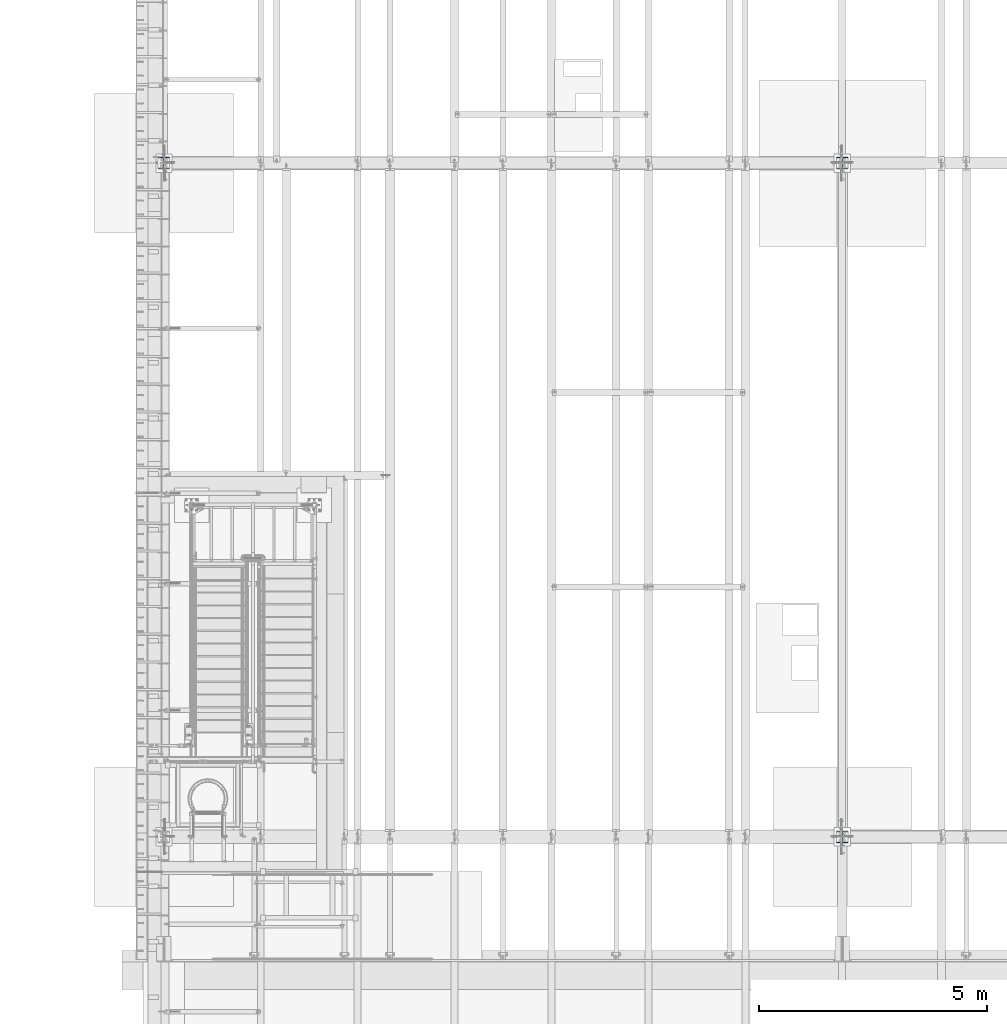
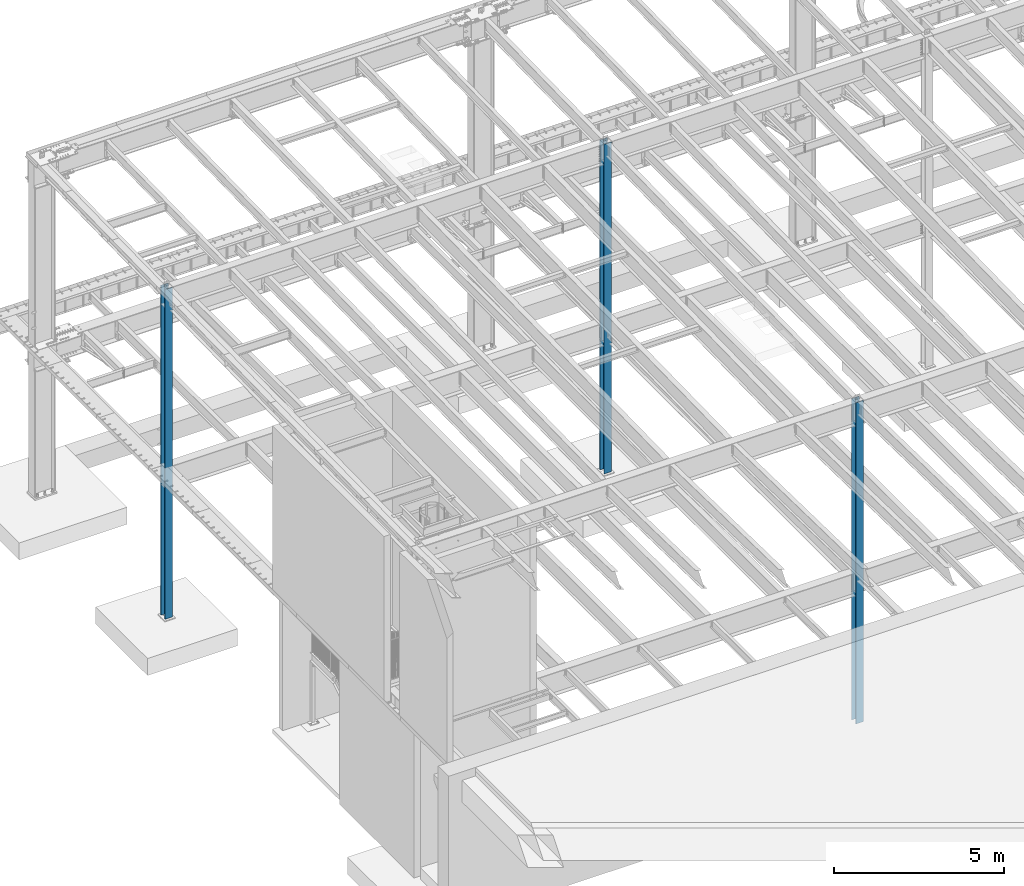
# One storey, part 907 of 1763: 3 columns, 3 elements without a shape of their own.
"""IFC2X3 building model written with IfcOpenShell, lengths in millimetres."""

import ifcopenshell
import ifcopenshell.guid

model = None  # the IFC model being written
_history = None  # IfcOwnerHistory: only IFC2X3 demands one
_inside = {}  # id of a spatial element -> (the spatial element, [elements in it])
_under = {}  # id of a project, library or spatial element -> (it, [spatial elements below it])
_declared = {}  # id of a project -> (the project, [libraries it declares])
_typed = {}  # id of a type object -> (the type object, [elements of that type])
_made_of = {}  # id of a material, layer set ... -> (it, [elements and type objects made of it])


def new_model(schema):
    """Start an empty IFC model of exactly this schema.

    Asked for "IFC4X3", IfcOpenShell would pick the latest addendum, in which some entities
    have other attributes; the version numbers below select the first issue.
    IFC2X3 requires an IfcOwnerHistory on every rooted entity: one is made here for all.
    """
    global model, _history
    if schema == "IFC4X3":
        model = ifcopenshell.file(schema_version=(4, 3, 0, 0))
    else:
        model = ifcopenshell.file(schema=schema)
    _inside.clear()
    _under.clear()
    _declared.clear()
    _typed.clear()
    _made_of.clear()
    _history = None
    if model.schema == "IFC2X3":
        org = make("IfcOrganization", Name="unknown")
        user = make(
            "IfcPersonAndOrganization",
            ThePerson=make("IfcPerson", FamilyName="unknown"),
            TheOrganization=org,
        )
        app = make(
            "IfcApplication",
            ApplicationDeveloper=org,
            Version="unknown",
            ApplicationFullName="unknown",
            ApplicationIdentifier="unknown",
        )
        _history = make(
            "IfcOwnerHistory",
            OwningUser=user,
            OwningApplication=app,
            ChangeAction="ADDED",
            CreationDate=0,
        )
    return model


def make(cls, **values):
    """One entity of the class cls with the attributes given. An attribute that is None is left unset."""
    return model.create_entity(
        cls, **{name: value for name, value in values.items() if value is not None}
    )


def rooted(cls, **values):
    """An entity with a GlobalId (a new one), such as an element, a storey or a relation."""
    return make(cls, GlobalId=ifcopenshell.guid.new(), OwnerHistory=_history, **values)


def si_unit(unit_type, name, prefix=None):
    """IfcSIUnit, for example si_unit("LENGTHUNIT", "METRE", prefix="MILLI")."""
    return make("IfcSIUnit", UnitType=unit_type, Prefix=prefix, Name=name)


def assignment(units):
    """IfcUnitAssignment: the units of a project."""
    return None if units is None else make("IfcUnitAssignment", Units=units)


def point(xyz):
    """IfcCartesianPoint."""
    return None if xyz is None else make("IfcCartesianPoint", Coordinates=xyz)


def direction(xyz):
    """IfcDirection."""
    return None if xyz is None else make("IfcDirection", DirectionRatios=xyz)


def frame(location, z_axis=None, x_axis=None):
    """IfcAxis2Placement3D, a coordinate frame: its origin and axes. An axis left out is left unset."""
    return make(
        "IfcAxis2Placement3D",
        Location=point(location),
        Axis=direction(z_axis),
        RefDirection=direction(x_axis),
    )


def origin_with_axes():
    """The frame at (0, 0, 0) with the z axis (0, 0, 1) and the x axis (1, 0, 0) written out."""
    return frame((0.0, 0.0, 0.0), z_axis=(0.0, 0.0, 1.0), x_axis=(1.0, 0.0, 0.0))


def place(relative_to, where):
    """IfcLocalPlacement: puts the frame where relative to a parent placement (None: the world)."""
    return make(
        "IfcLocalPlacement", PlacementRelTo=relative_to, RelativePlacement=where
    )


def context(
    kind, dimensions, precision=None, world=None, true_north=None, identifier=None
):
    """IfcGeometricRepresentationContext, for example the 3D "Model" context."""
    return make(
        "IfcGeometricRepresentationContext",
        ContextIdentifier=identifier,
        ContextType=kind,
        CoordinateSpaceDimension=dimensions,
        Precision=precision,
        WorldCoordinateSystem=world,
        TrueNorth=true_north,
    )


def subcontext(parent, identifier, kind, view, scale=None):
    """IfcGeometricRepresentationSubContext, for example "Body" below "Model"."""
    return make(
        "IfcGeometricRepresentationSubContext",
        ContextIdentifier=identifier,
        ContextType=kind,
        ParentContext=parent,
        TargetScale=scale,
        TargetView=view,
    )


def project(units=None, contexts=None):
    """IfcProject with its units and contexts."""
    return rooted(
        "IfcProject",
        Name="project",
        RepresentationContexts=contexts,
        UnitsInContext=assignment(units),
    )


def spatial(cls, under=None, at=None, **own):
    """A site, building, storey or space (cls), placed at a placement, below another one or the project."""
    s = rooted(cls, ObjectPlacement=at, **own)
    if under is not None:
        _under.setdefault(under.id(), (under, []))[1].append(s)
    return s


def faces_of(points, faces, orient=None, outer=None):
    """IfcFace entities. A face is a list of loops; a loop is a list of indices into points, from 0.

    orient and outer hold one flag for each loop. By default every Orientation is true, the
    first loop of a face is its IfcFaceOuterBound and the others are IfcFaceBound.
    """
    made = []
    for i, loops in enumerate(faces):
        bounds = []
        for j, loop in enumerate(loops):
            is_outer = j == 0 if outer is None else outer[i][j]
            bounds.append(
                make(
                    "IfcFaceOuterBound" if is_outer else "IfcFaceBound",
                    Bound=make("IfcPolyLoop", Polygon=[points[k] for k in loop]),
                    Orientation=True if orient is None else orient[i][j],
                )
            )
        made.append(make("IfcFace", Bounds=bounds))
    return made


def faceted_brep(points, faces, orient=None, outer=None, voids=None):
    """IfcFacetedBrep: a solid bounded by flat faces; with voids (closed shells), ...WithVoids."""
    shared = [point(p) for p in points]
    hull = make("IfcClosedShell", CfsFaces=faces_of(shared, faces, orient, outer))
    if voids is None:
        return make("IfcFacetedBrep", Outer=hull)
    return make(
        "IfcFacetedBrepWithVoids",
        Outer=hull,
        Voids=[
            make(cls, CfsFaces=faces_of(shared, fs, o, b)) for cls, fs, o, b in voids
        ],
    )


def shape(context_of_items, identifier, shape_type, items):
    """IfcShapeRepresentation: the items that make up one representation, for example the "Body"."""
    return make(
        "IfcShapeRepresentation",
        ContextOfItems=context_of_items,
        RepresentationIdentifier=identifier,
        RepresentationType=shape_type,
        Items=items,
    )


def material(Name=None, Category=None):
    """IfcMaterial."""
    return make("IfcMaterial", Name=Name, Category=Category)


def made_of(thing, what):
    """Note that an element or type object is made of a material, layer set ...; save() writes the relation."""
    if what is not None:
        _made_of.setdefault(what.id(), (what, []))[1].append(thing)
    return thing


def type_object(cls, material=None, **own):
    """A type object (cls), such as IfcWallType, which elements share."""
    return made_of(rooted(cls, **own), material)


def element(
    cls,
    number,
    at=None,
    inside=None,
    cuts=None,
    type_object=None,
    material=None,
    context=None,
    identifier="Body",
    shape_type=None,
    held_by="IfcProductDefinitionShape",
    body=None,
    shapes=None,
    **own,
):
    """One element of the class cls, such as IfcWall. Its Tag is "e" and its number.

    at: its placement. inside: the storey or other place that contains it. cuts: it is an
    opening in that element (IfcRelVoidsElement). A single representation is given by context,
    identifier, shape_type and body (its items); several are given by shapes. held_by: the class
    of the entity that holds the representations. save() writes the other relations.
    """
    e = rooted(cls, Tag="e%d" % number, ObjectPlacement=at, **own)
    if body is not None:
        shapes = [shape(context, identifier, shape_type, body)]
    if shapes is not None:
        e.Representation = make(held_by, Representations=shapes)
    if inside is not None:
        _inside.setdefault(inside.id(), (inside, []))[1].append(e)
    if cuts is not None:
        rooted(
            "IfcRelVoidsElement", RelatingBuildingElement=cuts, RelatedOpeningElement=e
        )
    if type_object is not None:
        _typed.setdefault(type_object.id(), (type_object, []))[1].append(e)
    return made_of(e, material)


def aggregate(whole, parts):
    """IfcRelAggregates: a whole, such as a stair, and the parts it consists of."""
    return rooted("IfcRelAggregates", RelatingObject=whole, RelatedObjects=parts)


def save(model, path):
    """Write the relations noted so far, then the file.

    IfcRelAggregates (storeys below a building ...), IfcRelContainedInSpatialStructure (elements
    in a storey), IfcRelDefinesByType, IfcRelAssociatesMaterial and IfcRelDeclares: one each for
    every whole, place, type object, material and project.
    """
    for whole, parts in _under.values():
        aggregate(whole, parts)
    for where, things in _inside.values():
        rooted(
            "IfcRelContainedInSpatialStructure",
            RelatedElements=things,
            RelatingStructure=where,
        )
    for kind, things in _typed.values():
        rooted("IfcRelDefinesByType", RelatedObjects=things, RelatingType=kind)
    for what, things in _made_of.values():
        rooted("IfcRelAssociatesMaterial", RelatedObjects=things, RelatingMaterial=what)
    for by, libraries in _declared.values():
        rooted("IfcRelDeclares", RelatingContext=by, RelatedDefinitions=libraries)
    model.write(path)


model = new_model("IFC2X3")

# Units and contexts
model_context = context("Model", 3, precision=1e-05, world=origin_with_axes())
body_context = subcontext(model_context, "Body", "Model", "MODEL_VIEW")
ifc_project = project(units=[si_unit("LENGTHUNIT", "METRE", prefix="MILLI"), si_unit("AREAUNIT", "SQUARE_METRE"), si_unit("VOLUMEUNIT", "CUBIC_METRE"), si_unit("MASSUNIT", "GRAM", prefix="KILO"), si_unit("TIMEUNIT", "SECOND"), si_unit("PLANEANGLEUNIT", "RADIAN"), si_unit("SOLIDANGLEUNIT", "STERADIAN"), si_unit("THERMODYNAMICTEMPERATUREUNIT", "DEGREE_CELSIUS"), si_unit("LUMINOUSINTENSITYUNIT", "LUMEN")], contexts=[model_context])

# Site, building, storey
site_placement = place(None, origin_with_axes())
site = spatial("IfcSite", under=ifc_project, at=site_placement, CompositionType="ELEMENT")
building_placement = place(site_placement, origin_with_axes())
building = spatial("IfcBuilding", under=site, at=building_placement, Name="Undefined", CompositionType="ELEMENT")
storey_placement = place(building_placement, origin_with_axes())
storey = spatial("IfcBuildingStorey", under=building, at=storey_placement, Name="Undefined", CompositionType="ELEMENT", Elevation=0.0)

# Assembly, column
assembly_1_placement = place(storey_placement, origin_with_axes())
assembly_1 = element("IfcElementAssembly", 1, at=assembly_1_placement, inside=storey, Name="COLUMN", AssemblyPlace="NOTDEFINED", PredefinedType="RIGID_FRAME")
ifc_material = material(Name="STEEL/A992")
column_type = type_object("IfcColumnType", Name="W10X68", PredefinedType="NOTDEFINED")
column_1_placement = place(assembly_1_placement, frame((-72491.0372736983, 30022.8, -304.8), z_axis=(0.0, 1.0, 0.0), x_axis=(0.0, 0.0, 1.0)))
column_1 = element("IfcColumn", 2, at=column_1_placement, type_object=column_type, material=ifc_material, Name="COLUMN", ObjectType="W10X68", context=body_context, shape_type="Brep", body=[
    faceted_brep([(69.8499999999952, 128.587499999994, -131.762500000001), (69.8499999999952, 128.587499999994, -112.712500000001), (11582.3999999952, 128.587499999994, -112.712500000001), (11582.3999999952, 128.587499999994, -131.762500000001), (69.8499999999952, 6.35000000000582, -112.712500000001), (11582.3999999952, 6.35000000000582, -112.712500000001), (69.8499999999952, 6.35000000000582, 112.712500000001), (11582.3999999952, 6.35000000000582, 112.712500000001), (69.8499999999952, 128.587499999994, 112.712500000001), (11582.3999999952, 128.587499999994, 112.712500000001), (69.8499999999952, 128.587499999994, 131.762500000001), (11582.3999999952, 128.587499999994, 131.762500000001), (69.8499999999952, -128.587499999994, 131.762500000001), (11582.3999999952, -128.587499999994, 131.762500000001), (69.8499999999952, -128.587499999994, 112.712500000001), (11582.3999999952, -128.587499999994, 112.712500000001), (69.8499999999952, -6.35000000000582, 112.712500000001), (11582.3999999952, -6.35000000000582, 112.712500000001), (69.8499999999952, -6.35000000000582, -112.712500000001), (11582.3999999952, -6.35000000000582, -112.712500000001), (69.8499999999952, -128.587499999994, -112.712500000001), (11582.3999999952, -128.587499999994, -112.712500000001), (69.8499999999952, -128.587499999994, -131.762500000001), (11582.3999999952, -128.587499999994, -131.762500000001)], [[[0, 1, 2, 3]], [[1, 4, 5, 2]], [[4, 6, 7, 5]], [[6, 8, 9, 7]], [[8, 10, 11, 9]], [[10, 12, 13, 11]], [[12, 14, 15, 13]], [[14, 16, 17, 15]], [[16, 18, 19, 17]], [[18, 20, 21, 19]], [[20, 22, 23, 21]], [[22, 0, 3, 23]], [[5, 7, 9, 11, 13, 15, 17, 19, 21, 23, 3, 2]], [[22, 20, 18, 16, 14, 12, 10, 8, 6, 4, 1, 0]]]),
])
aggregate(assembly_1, [column_1])

assembly_2_placement = place(storey_placement, origin_with_axes())
assembly_2 = element("IfcElementAssembly", 3, at=assembly_2_placement, inside=storey, Name="COLUMN", AssemblyPlace="NOTDEFINED", PredefinedType="RIGID_FRAME")
column_2_placement = place(assembly_2_placement, frame((-72491.0372736983, 44805.6, -304.8), z_axis=(0.0, 1.0, 0.0), x_axis=(0.0, 0.0, 1.0)))
column_2 = element("IfcColumn", 4, at=column_2_placement, type_object=column_type, material=ifc_material, Name="COLUMN", ObjectType="W10X68", context=body_context, shape_type="Brep", body=[
    faceted_brep([(69.8499999999952, 128.587499999994, -131.762500000001), (69.8499999999952, 128.587499999994, -112.712500000001), (11887.795312, 128.587500000001, -112.712500000001), (11887.795312, 128.587500000001, -131.762499999997), (69.8499999999952, 6.35000000000582, -112.712500000001), (11887.795312, 6.34999999999854, -112.712500000001), (69.8499999999952, 6.35000000000582, 112.712500000001), (11887.795312, 6.34999999999854, 112.712500000001), (69.8499999999952, 128.587499999994, 112.712500000001), (11887.795312, 128.587500000001, 112.712500000001), (69.8499999999952, 128.587499999994, 131.762500000001), (11887.795312, 128.587500000001, 131.762499999997), (69.8499999999952, -128.587499999994, 131.762500000001), (11887.795312, -128.587500000001, 131.762499999997), (69.8499999999952, -128.587499999994, 112.712500000001), (11887.795312, -128.587500000001, 112.712500000001), (69.8499999999952, -6.35000000000582, 112.712500000001), (11887.795312, -6.34999999999854, 112.712500000001), (69.8499999999952, -6.35000000000582, -112.712500000001), (11887.795312, -6.34999999999854, -112.712500000001), (69.8499999999952, -128.587499999994, -112.712500000001), (11887.795312, -128.587500000001, -112.712500000001), (69.8499999999952, -128.587499999994, -131.762500000001), (11887.795312, -128.587500000001, -131.762499999997)], [[[0, 1, 2, 3]], [[1, 4, 5, 2]], [[4, 6, 7, 5]], [[6, 8, 9, 7]], [[8, 10, 11, 9]], [[10, 12, 13, 11]], [[12, 14, 15, 13]], [[14, 16, 17, 15]], [[16, 18, 19, 17]], [[18, 20, 21, 19]], [[20, 22, 23, 21]], [[22, 0, 3, 23]], [[5, 7, 9, 11, 13, 15, 17, 19, 21, 23, 3, 2]], [[22, 20, 18, 16, 14, 12, 10, 8, 6, 4, 1, 0]]]),
])
aggregate(assembly_2, [column_2])

assembly_3_placement = place(storey_placement, origin_with_axes())
assembly_3 = element("IfcElementAssembly", 5, at=assembly_3_placement, inside=storey, Name="COLUMN", AssemblyPlace="NOTDEFINED", PredefinedType="RIGID_FRAME")
column_3_placement = place(assembly_3_placement, frame((-87375.4372736983, 44805.6, -304.8), z_axis=(0.0, 1.0, 0.0), x_axis=(0.0, 0.0, 1.0)))
column_3 = element("IfcColumn", 6, at=column_3_placement, type_object=column_type, material=ifc_material, Name="COLUMN", ObjectType="W10X68", context=body_context, shape_type="Brep", body=[
    faceted_brep([(69.8499999999952, 128.587499999994, -131.762500000001), (69.8499999999952, 128.587499999994, -112.712500000001), (11887.795312, 128.587500000001, -112.712500000001), (11887.795312, 128.587500000001, -131.762499999997), (69.8499999999952, 6.35000000000582, -112.712500000001), (11887.795312, 6.34999999999854, -112.712500000001), (69.8499999999952, 6.35000000000582, 112.712500000001), (11887.795312, 6.34999999999854, 112.712500000001), (69.8499999999952, 128.587499999994, 112.712500000001), (11887.795312, 128.587500000001, 112.712500000001), (69.8499999999952, 128.587499999994, 131.762500000001), (11887.795312, 128.587500000001, 131.762499999997), (69.8499999999952, -128.587499999994, 131.762500000001), (11887.795312, -128.587500000001, 131.762499999997), (69.8499999999952, -128.587499999994, 112.712500000001), (11887.795312, -128.587500000001, 112.712500000001), (69.8499999999952, -6.35000000000582, 112.712500000001), (11887.795312, -6.34999999999854, 112.712500000001), (69.8499999999952, -6.35000000000582, -112.712500000001), (11887.795312, -6.34999999999854, -112.712500000001), (69.8499999999952, -128.587499999994, -112.712500000001), (11887.795312, -128.587500000001, -112.712500000001), (69.8499999999952, -128.587499999994, -131.762500000001), (11887.795312, -128.587500000001, -131.762499999997)], [[[0, 1, 2, 3]], [[1, 4, 5, 2]], [[4, 6, 7, 5]], [[6, 8, 9, 7]], [[8, 10, 11, 9]], [[10, 12, 13, 11]], [[12, 14, 15, 13]], [[14, 16, 17, 15]], [[16, 18, 19, 17]], [[18, 20, 21, 19]], [[20, 22, 23, 21]], [[22, 0, 3, 23]], [[5, 7, 9, 11, 13, 15, 17, 19, 21, 23, 3, 2]], [[22, 20, 18, 16, 14, 12, 10, 8, 6, 4, 1, 0]]]),
])
aggregate(assembly_3, [column_3])

save(model, "model.ifc")
